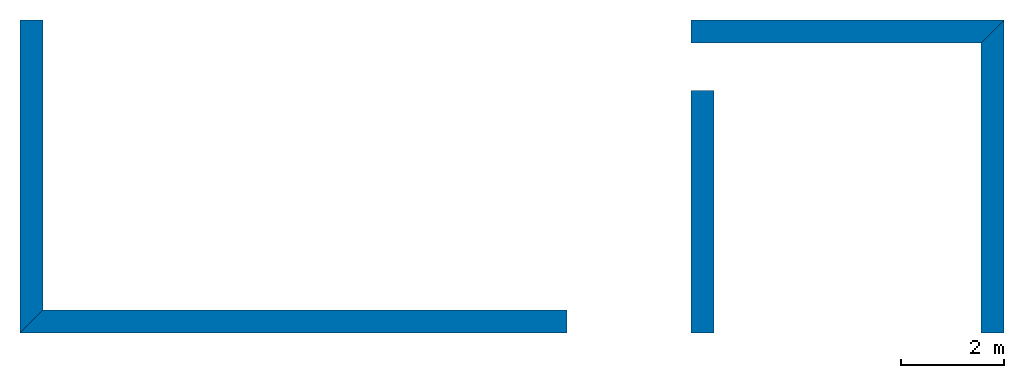
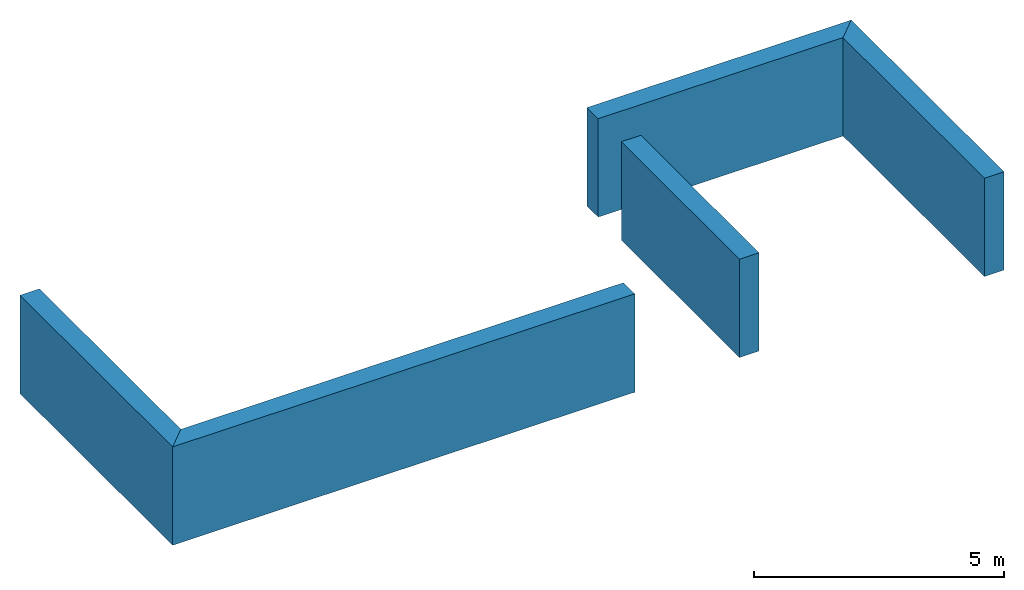
# One storey: 5 walls.
"""IFC4 building model written with IfcOpenShell, lengths in metres."""

import ifcopenshell
import ifcopenshell.guid

model = None  # the IFC model being written
_history = None  # IfcOwnerHistory: only IFC2X3 demands one
_inside = {}  # id of a spatial element -> (the spatial element, [elements in it])
_under = {}  # id of a project, library or spatial element -> (it, [spatial elements below it])
_declared = {}  # id of a project -> (the project, [libraries it declares])
_typed = {}  # id of a type object -> (the type object, [elements of that type])
_made_of = {}  # id of a material, layer set ... -> (it, [elements and type objects made of it])


def new_model(schema):
    """Start an empty IFC model of exactly this schema.

    Asked for "IFC4X3", IfcOpenShell would pick the latest addendum, in which some entities
    have other attributes; the version numbers below select the first issue.
    IFC2X3 requires an IfcOwnerHistory on every rooted entity: one is made here for all.
    """
    global model, _history
    if schema == "IFC4X3":
        model = ifcopenshell.file(schema_version=(4, 3, 0, 0))
    else:
        model = ifcopenshell.file(schema=schema)
    _inside.clear()
    _under.clear()
    _declared.clear()
    _typed.clear()
    _made_of.clear()
    _history = None
    if model.schema == "IFC2X3":
        org = make("IfcOrganization", Name="unknown")
        user = make(
            "IfcPersonAndOrganization",
            ThePerson=make("IfcPerson", FamilyName="unknown"),
            TheOrganization=org,
        )
        app = make(
            "IfcApplication",
            ApplicationDeveloper=org,
            Version="unknown",
            ApplicationFullName="unknown",
            ApplicationIdentifier="unknown",
        )
        _history = make(
            "IfcOwnerHistory",
            OwningUser=user,
            OwningApplication=app,
            ChangeAction="ADDED",
            CreationDate=0,
        )
    return model


def make(cls, **values):
    """One entity of the class cls with the attributes given. An attribute that is None is left unset."""
    return model.create_entity(
        cls, **{name: value for name, value in values.items() if value is not None}
    )


def entity(cls, *values):
    """Any entity or typed value of the class cls, its attributes in the order of the schema. None: left unset."""
    e = model.create_entity(cls)
    for i, value in enumerate(values):
        if value is not None:
            e[i] = value
    return e


def rooted(cls, **values):
    """An entity with a GlobalId (a new one), such as an element, a storey or a relation."""
    return make(cls, GlobalId=ifcopenshell.guid.new(), OwnerHistory=_history, **values)


def si_unit(unit_type, name, prefix=None):
    """IfcSIUnit, for example si_unit("LENGTHUNIT", "METRE", prefix="MILLI")."""
    return make("IfcSIUnit", UnitType=unit_type, Prefix=prefix, Name=name)


def converted_unit(unit_type, name, factor, base, dimensions=None, offset=None):
    """IfcConversionBasedUnit, such as the inch: factor (a typed value) times the base unit."""
    return make(
        "IfcConversionBasedUnit"
        if offset is None
        else "IfcConversionBasedUnitWithOffset",
        ConversionOffset=offset,
        Dimensions=None
        if dimensions is None
        else entity("IfcDimensionalExponents", *dimensions),
        UnitType=unit_type,
        Name=name,
        ConversionFactor=make(
            "IfcMeasureWithUnit", ValueComponent=factor, UnitComponent=base
        ),
    )


def assignment(units):
    """IfcUnitAssignment: the units of a project."""
    return None if units is None else make("IfcUnitAssignment", Units=units)


def point(xyz):
    """IfcCartesianPoint."""
    return None if xyz is None else make("IfcCartesianPoint", Coordinates=xyz)


def direction(xyz):
    """IfcDirection."""
    return None if xyz is None else make("IfcDirection", DirectionRatios=xyz)


def frame(location, z_axis=None, x_axis=None):
    """IfcAxis2Placement3D, a coordinate frame: its origin and axes. An axis left out is left unset."""
    return make(
        "IfcAxis2Placement3D",
        Location=point(location),
        Axis=direction(z_axis),
        RefDirection=direction(x_axis),
    )


def frame_2d(location, x_axis=None):
    """IfcAxis2Placement2D, a coordinate frame in the plane: its origin and x axis."""
    return make(
        "IfcAxis2Placement2D", Location=point(location), RefDirection=direction(x_axis)
    )


def origin_with_axes():
    """The frame at (0, 0, 0) with the z axis (0, 0, 1) and the x axis (1, 0, 0) written out."""
    return frame((0.0, 0.0, 0.0), z_axis=(0.0, 0.0, 1.0), x_axis=(1.0, 0.0, 0.0))


def place(relative_to, where):
    """IfcLocalPlacement: puts the frame where relative to a parent placement (None: the world)."""
    return make(
        "IfcLocalPlacement", PlacementRelTo=relative_to, RelativePlacement=where
    )


def context(
    kind, dimensions, precision=None, world=None, true_north=None, identifier=None
):
    """IfcGeometricRepresentationContext, for example the 3D "Model" context."""
    return make(
        "IfcGeometricRepresentationContext",
        ContextIdentifier=identifier,
        ContextType=kind,
        CoordinateSpaceDimension=dimensions,
        Precision=precision,
        WorldCoordinateSystem=world,
        TrueNorth=true_north,
    )


def subcontext(parent, identifier, kind, view, scale=None):
    """IfcGeometricRepresentationSubContext, for example "Body" below "Model"."""
    return make(
        "IfcGeometricRepresentationSubContext",
        ContextIdentifier=identifier,
        ContextType=kind,
        ParentContext=parent,
        TargetScale=scale,
        TargetView=view,
    )


def project(units=None, contexts=None):
    """IfcProject with its units and contexts."""
    return rooted(
        "IfcProject",
        Name="project",
        RepresentationContexts=contexts,
        UnitsInContext=assignment(units),
    )


def spatial(cls, under=None, at=None, **own):
    """A site, building, storey or space (cls), placed at a placement, below another one or the project."""
    s = rooted(cls, ObjectPlacement=at, **own)
    if under is not None:
        _under.setdefault(under.id(), (under, []))[1].append(s)
    return s


def polyline(points):
    """IfcPolyline through the points."""
    return make("IfcPolyline", Points=[point(p) for p in points])


def outline(outer, holes=None, kind="AREA"):
    """IfcArbitraryClosedProfileDef: a profile drawn as a closed curve; with holes, ...WithVoids."""
    if holes is None:
        return make("IfcArbitraryClosedProfileDef", ProfileType=kind, OuterCurve=outer)
    return make(
        "IfcArbitraryProfileDefWithVoids",
        ProfileType=kind,
        OuterCurve=outer,
        InnerCurves=holes,
    )


def extrude(swept, where, along, depth):
    """IfcExtrudedAreaSolid: the profile swept, set in the frame where, extruded along a direction by depth."""
    return make(
        "IfcExtrudedAreaSolid",
        SweptArea=swept,
        Position=where,
        ExtrudedDirection=direction(along),
        Depth=depth,
    )


def shape(context_of_items, identifier, shape_type, items):
    """IfcShapeRepresentation: the items that make up one representation, for example the "Body"."""
    return make(
        "IfcShapeRepresentation",
        ContextOfItems=context_of_items,
        RepresentationIdentifier=identifier,
        RepresentationType=shape_type,
        Items=items,
    )


def material(Name=None, Category=None):
    """IfcMaterial."""
    return make("IfcMaterial", Name=Name, Category=Category)


def layer(
    of_material, thickness, ventilated=None, Name=None, Category=None, Priority=None
):
    """IfcMaterialLayer: one layer of a wall or slab, of a material (None: an air gap)."""
    return make(
        "IfcMaterialLayer",
        Material=of_material,
        LayerThickness=thickness,
        IsVentilated=ventilated,
        Name=Name,
        Category=Category,
        Priority=Priority,
    )


def layer_set(layers, Name=None):
    """IfcMaterialLayerSet."""
    return make("IfcMaterialLayerSet", MaterialLayers=layers, LayerSetName=Name)


def layer_usage(for_layer_set, set_direction, sense, offset, extent=None):
    """IfcMaterialLayerSetUsage: how a layer set lies in its element."""
    return make(
        "IfcMaterialLayerSetUsage",
        ForLayerSet=for_layer_set,
        LayerSetDirection=set_direction,
        DirectionSense=sense,
        OffsetFromReferenceLine=offset,
        ReferenceExtent=extent,
    )


def made_of(thing, what):
    """Note that an element or type object is made of a material, layer set ...; save() writes the relation."""
    if what is not None:
        _made_of.setdefault(what.id(), (what, []))[1].append(thing)
    return thing


def type_object(cls, material=None, **own):
    """A type object (cls), such as IfcWallType, which elements share."""
    return made_of(rooted(cls, **own), material)


def element(
    cls,
    number,
    at=None,
    inside=None,
    cuts=None,
    type_object=None,
    material=None,
    context=None,
    identifier="Body",
    shape_type=None,
    held_by="IfcProductDefinitionShape",
    body=None,
    shapes=None,
    **own,
):
    """One element of the class cls, such as IfcWall. Its Tag is "e" and its number.

    at: its placement. inside: the storey or other place that contains it. cuts: it is an
    opening in that element (IfcRelVoidsElement). A single representation is given by context,
    identifier, shape_type and body (its items); several are given by shapes. held_by: the class
    of the entity that holds the representations. save() writes the other relations.
    """
    e = rooted(cls, Tag="e%d" % number, ObjectPlacement=at, **own)
    if body is not None:
        shapes = [shape(context, identifier, shape_type, body)]
    if shapes is not None:
        e.Representation = make(held_by, Representations=shapes)
    if inside is not None:
        _inside.setdefault(inside.id(), (inside, []))[1].append(e)
    if cuts is not None:
        rooted(
            "IfcRelVoidsElement", RelatingBuildingElement=cuts, RelatedOpeningElement=e
        )
    if type_object is not None:
        _typed.setdefault(type_object.id(), (type_object, []))[1].append(e)
    return made_of(e, material)


def aggregate(whole, parts):
    """IfcRelAggregates: a whole, such as a stair, and the parts it consists of."""
    return rooted("IfcRelAggregates", RelatingObject=whole, RelatedObjects=parts)


def save(model, path):
    """Write the relations noted so far, then the file.

    IfcRelAggregates (storeys below a building ...), IfcRelContainedInSpatialStructure (elements
    in a storey), IfcRelDefinesByType, IfcRelAssociatesMaterial and IfcRelDeclares: one each for
    every whole, place, type object, material and project.
    """
    for whole, parts in _under.values():
        aggregate(whole, parts)
    for where, things in _inside.values():
        rooted(
            "IfcRelContainedInSpatialStructure",
            RelatedElements=things,
            RelatingStructure=where,
        )
    for kind, things in _typed.values():
        rooted("IfcRelDefinesByType", RelatedObjects=things, RelatingType=kind)
    for what, things in _made_of.values():
        rooted("IfcRelAssociatesMaterial", RelatedObjects=things, RelatingMaterial=what)
    for by, libraries in _declared.values():
        rooted("IfcRelDeclares", RelatingContext=by, RelatedDefinitions=libraries)
    model.write(path)


model = new_model("IFC4")

# Units and contexts
model_context = context("Model", 3, precision=1e-05, world=origin_with_axes())
plan_context = context("Plan", 2, precision=1e-05, world=frame_2d((0.0, 0.0, 0.0), x_axis=(1.0, 0.0, 0.0)))
body_context = subcontext(model_context, "Body", "Model", "MODEL_VIEW")
ifc_project = project(units=[si_unit("VOLUMEUNIT", "CUBIC_METRE"), si_unit("LENGTHUNIT", "METRE"), converted_unit("PLANEANGLEUNIT", "degree", entity("IfcReal", 0.0174532925199433), si_unit("PLANEANGLEUNIT", "RADIAN"), dimensions=[0, 0, 0, 0, 0, 0, 0]), si_unit("AREAUNIT", "SQUARE_METRE")], contexts=[model_context, plan_context])

# Site, building, storey
site_placement = place(None, origin_with_axes())
site = spatial("IfcSite", under=ifc_project, at=site_placement)
building_placement = place(site_placement, origin_with_axes())
building = spatial("IfcBuilding", under=site, at=building_placement, Name="Building")
storey_placement = place(building_placement, origin_with_axes())
storey = spatial("IfcBuildingStorey", under=building, at=storey_placement, Name="00")

# Walls
ifc_material = material()
ifc_layer = layer(ifc_material, 0.449999988079071)
ifc_layer_set = layer_set([ifc_layer])
ifc_layer_usage_1 = layer_usage(ifc_layer_set, "AXIS2", "POSITIVE", 0.0)
wall_type = type_object("IfcWallType", Name="450mm", PredefinedType="SOLIDWALL", material=ifc_layer_set)
wall_1_placement = place(storey_placement, frame((5.09999990463257, 3.59999990463257, 0.0), z_axis=(0.0, 0.0, 1.0), x_axis=(1.0, 0.0, 0.0)))
element("IfcWall", 1, at=wall_1_placement, inside=storey, type_object=wall_type, material=ifc_layer_usage_1, Name="Wall", context=body_context, shape_type="SweptSolid", body=[
    extrude(outline(polyline([(-0.224999904632568, -5.22000026702881), (0.224999904632568, -5.22000026702881), (0.224999904632568, 5.44500064849854), (-0.224999904632568, 4.9950008392334), (-0.224999904632568, -5.22000026702881)])), frame((5.44500064849854, 0.224999904632568, 0.0), z_axis=(0.0, 0.0, -1.0), x_axis=(0.0, -1.0, 0.0)), (0.0, 0.0, -1.0), 2.40000004768372),
])
ifc_layer_usage_2 = layer_usage(ifc_layer_set, "AXIS2", "POSITIVE", 0.0)
wall_2_placement = place(storey_placement, frame((5.09999990463257, 9.69999980926514, 0.0), z_axis=(0.0, 0.0, 1.0), x_axis=(-1.62920684942947e-07, -1.0, 0.0)))
element("IfcWall", 2, at=wall_2_placement, inside=storey, type_object=wall_type, material=ifc_layer_usage_2, Name="Wall", context=body_context, shape_type="SweptSolid", body=[
    extrude(outline(polyline([(1.75892841815948, -2.07712626457214), (2.39532399177551, -2.07712602615356), (-1.91802728176117, 2.23622512817383), (-2.23622512817383, 1.91802728176117), (1.75892841815948, -2.07712626457214)])), frame((2.93749952316284, 0.225000083446503, 0.0), z_axis=(0.0, 0.0, -1.0), x_axis=(0.707106828689575, -0.70710676908493, 0.0)), (6.20881701607345e-09, 0.0, -1.0), 2.40000004768372),
])
ifc_layer_usage_3 = layer_usage(ifc_layer_set, "AXIS2", "POSITIVE", 0.0)
wall_3_placement = place(storey_placement, frame((24.2800025939941, 3.59500074386597, 0.0), z_axis=(0.0, 0.0, 1.0), x_axis=(1.94707183709397e-07, 1.0, 0.0)))
element("IfcWall", 3, at=wall_3_placement, inside=storey, type_object=wall_type, material=ifc_layer_usage_3, Name="Wall", context=body_context, shape_type="SweptSolid", body=[
    extrude(outline(polyline([(-0.225000813603401, -2.93999886512756), (0.22499917447567, -2.93999886512756), (0.22500067949295, 2.71499752998352), (-0.224999025464058, 3.16500020027161), (-0.225000813603401, -2.93999886512756)])), frame((2.93999886512756, 0.225000381469727, 0.0), z_axis=(0.0, 0.0, -1.0), x_axis=(8.74227765734759e-08, 1.0, 0.0)), (1.54296719845348e-09, -8.19589907052887e-09, -1.0), 2.40000004768372),
])
ifc_layer_usage_4 = layer_usage(ifc_layer_set, "AXIS2", "POSITIVE", 0.0)
wall_4_placement = place(storey_placement, frame((24.2800025939941, 9.70000267028809, 0.0), z_axis=(0.0, 0.0, 1.0), x_axis=(-1.0, 3.25841369885893e-07, 0.0)))
element("IfcWall", 4, at=wall_4_placement, inside=storey, type_object=wall_type, material=ifc_layer_usage_4, Name="Wall", context=body_context, shape_type="SweptSolid", body=[
    extrude(outline(polyline([(-0.224999397993088, -2.93749904632568), (0.224999442696571, -2.93749904632568), (0.225000381469727, 3.16249847412109), (-0.225000441074371, 2.71249985694885), (-0.224999397993088, -2.93749904632568)])), frame((3.16249847412109, 0.225000768899918, 0.0), z_axis=(0.0, 0.0, -1.0), x_axis=(0.0, -1.0, 0.0)), (0.0, 0.0, -1.0), 2.40000004768372),
])
ifc_layer_usage_5 = layer_usage(ifc_layer_set, "AXIS2", "POSITIVE", 0.0)
wall_5_placement = place(storey_placement, frame((18.180004119873, 8.32500457763672, 0.0), z_axis=(0.0, 0.0, 1.0), x_axis=(-1.62920684942947e-07, -1.0, 0.0)))
element("IfcWall", 5, at=wall_5_placement, inside=storey, type_object=wall_type, material=ifc_layer_usage_5, Name="Wall.002", context=body_context, shape_type="SweptSolid", body=[
    extrude(outline(polyline([(-0.224999979138374, -2.3625020980835), (0.225000008940697, -2.3625020980835), (0.225000366568565, 2.36250233650208), (-0.225000396370888, 2.36250233650208), (-0.224999979138374, -2.3625020980835)])), frame((2.36250305175781, 0.225000008940697, 0.0), z_axis=(0.0, 0.0, -1.0), x_axis=(0.0, -1.0, 0.0)), (0.0, 0.0, -1.0), 2.40000004768372),
])

save(model, "model.ifc")
